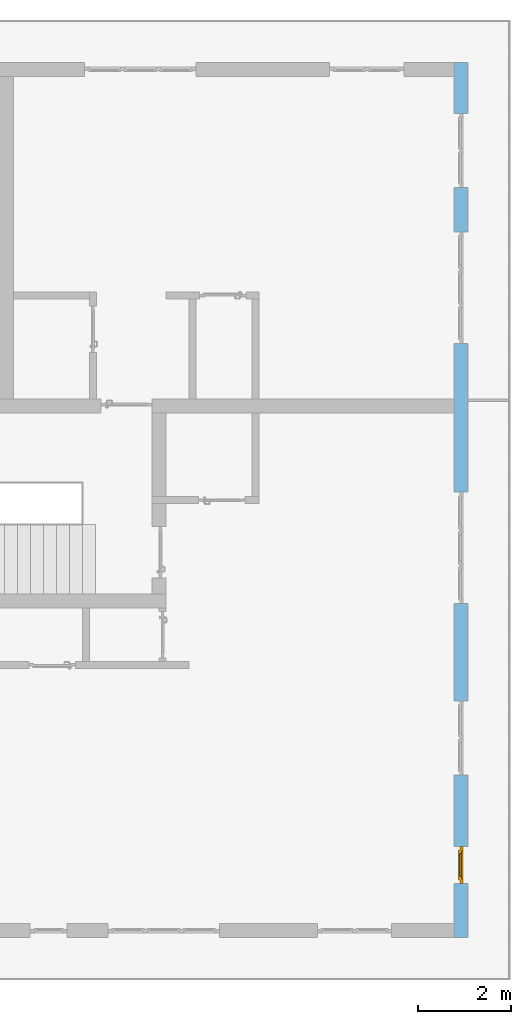
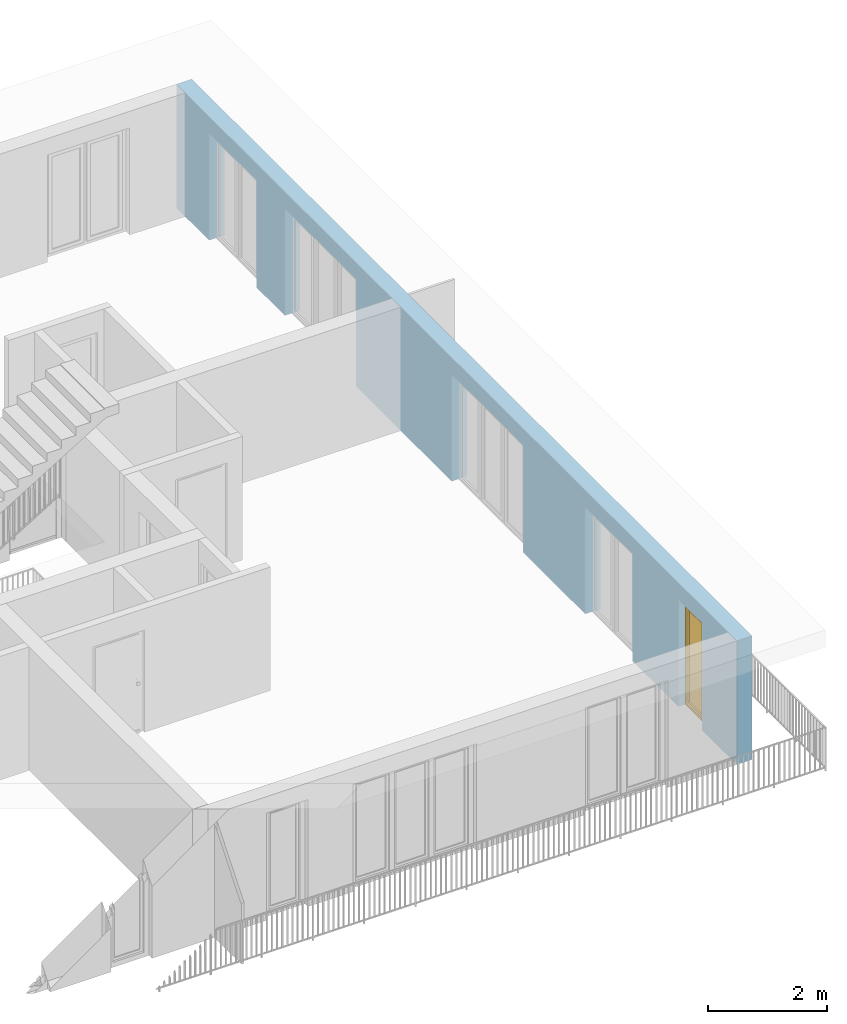
# One storey, part 19 of 48: 1 window, 5 openings, plus 1 element that does not belong to this part.
"""IFC4 building model written with IfcOpenShell, lengths in metres."""

from ifc_helpers import new_model, entity, si_unit, converted_unit, derived_unit, direction, frame, origin_with_axes, place, context, subcontext, project, spatial, polygons, source, transform, mapped, material, type_object, element, fill, save


model = new_model("IFC4")

# Units and contexts
model_context = context("Model", 3, precision=1e-05, world=origin_with_axes(), true_north=direction((0.0, 1.0)))
body_context = subcontext(model_context, "Body", "Model", "MODEL_VIEW")
ifc_project = project(units=[si_unit("LENGTHUNIT", "METRE"), si_unit("AREAUNIT", "SQUARE_METRE"), si_unit("VOLUMEUNIT", "CUBIC_METRE"), converted_unit("PLANEANGLEUNIT", "DEGREE", entity("IfcPlaneAngleMeasure", 0.0174532925199), si_unit("PLANEANGLEUNIT", "RADIAN"), dimensions=[0, 0, 0, 0, 0, 0, 0]), converted_unit("TIMEUNIT", "Year", entity("IfcTimeMeasure", 31556926.0), si_unit("TIMEUNIT", "SECOND"), dimensions=[0, 0, 1, 0, 0, 0, 0]), si_unit("MASSUNIT", "GRAM", prefix="KILO"), si_unit("THERMODYNAMICTEMPERATUREUNIT", "DEGREE_CELSIUS"), si_unit("LUMINOUSINTENSITYUNIT", "LUMEN"), si_unit("ENERGYUNIT", "JOULE", prefix="MEGA"), derived_unit("THERMALCONDUCTANCEUNIT", [(si_unit("POWERUNIT", "WATT"), 1), (si_unit("LENGTHUNIT", "METRE"), -1), (si_unit("THERMODYNAMICTEMPERATUREUNIT", "KELVIN"), -1)]), derived_unit("SPECIFICHEATCAPACITYUNIT", [(si_unit("ENERGYUNIT", "JOULE"), 1), (si_unit("MASSUNIT", "GRAM", prefix="KILO"), -1), (si_unit("THERMODYNAMICTEMPERATUREUNIT", "KELVIN"), -1)]), derived_unit("MASSDENSITYUNIT", [(si_unit("MASSUNIT", "GRAM", prefix="KILO"), 1), (si_unit("VOLUMEUNIT", "CUBIC_METRE"), -1)])], contexts=[model_context])

# Site, building, storey
site_placement = place(None, origin_with_axes())
site = spatial("IfcSite", under=ifc_project, at=site_placement, CompositionType="ELEMENT")
building_placement = place(site_placement, origin_with_axes())
building = spatial("IfcBuilding", under=site, at=building_placement, CompositionType="ELEMENT")
storey_placement = place(building_placement, frame((0.0, 0.0, 3.4), z_axis=(0.0, 0.0, 1.0), x_axis=(1.0, 0.0, 0.0)))
storey = spatial("IfcBuildingStorey", under=building, at=storey_placement, Name="1. Geschoss", CompositionType="ELEMENT", Elevation=3.4)

# Wall, openings, window
ifc_material = material()
wall_type = type_object("IfcWallType", Name="300", PredefinedType="NOTDEFINED")
wall_placement = place(storey_placement, frame((9.3378006196, -9.92881223104, 0.0), z_axis=(0.0, 0.0, 1.0), x_axis=(0.0, 1.0, 0.0)))
wall = element("IfcWall", 1, at=wall_placement, inside=storey, type_object=wall_type, material=ifc_material, Name="Wand-001", PredefinedType="NOTDEFINED", context=body_context, shape_type="Tessellation", body=[
    polygons([(1.16441876325, 0.1, 2.2), (1.96441876325, 0.1, 2.2), (1.96441876325, 0.0, 2.2), (1.16441876325, 0.0, 2.2), (1.16441876325, 0.3, 2.2), (1.96441876325, 0.3, 2.2), (1.96441876325, 0.1, 0.0), (1.96441876325, 0.0, 0.0), (18.85, 0.0, 2.54), (0.0, 0.0, 2.54), (0.0, 0.0, 0.0), (1.16441876325, 0.0, 0.0), (3.5, 0.0, 0.0), (3.5, 0.0, 2.2), (5.1, 0.0, 2.2), (5.1, 0.0, 0.0), (7.1921181063, 0.0, 0.0), (7.1921181063, 0.0, 2.2), (9.5921181063, 0.0, 2.2), (9.5921181063, 0.0, 0.0), (12.8, 0.0, 0.0), (12.8, 0.0, 2.2), (15.2, 0.0, 2.2), (15.2, 0.0, 0.0), (16.15, 0.0, 0.0), (16.15, 0.0, 2.2), (17.75, 0.0, 2.2), (17.75, 0.0, 0.0), (18.85, 0.0, 0.0), (1.16441876325, 0.1, 0.0), (1.16441876325, 0.3, 0.0), (0.0, 0.3, 0.0), (0.0, 0.3, 2.54), (18.85, 0.3, 2.54), (18.85, 0.3, 0.0), (17.75, 0.3, 0.0), (17.75, 0.3, 2.2), (16.15, 0.3, 2.2), (16.15, 0.3, 0.0), (15.2, 0.3, 0.0), (15.2, 0.3, 2.2), (12.8, 0.3, 2.2), (12.8, 0.3, 0.0), (9.5921181063, 0.3, 0.0), (9.5921181063, 0.3, 2.2), (7.1921181063, 0.3, 2.2), (7.1921181063, 0.3, 0.0), (5.1, 0.3, 0.0), (5.1, 0.3, 2.2), (3.5, 0.3, 2.2), (3.5, 0.3, 0.0), (1.96441876325, 0.3, 0.0), (3.5, 0.1, 0.0), (3.5, 0.1, 2.2), (5.1, 0.1, 2.2), (5.1, 0.1, 0.0), (7.1921181063, 0.1, 0.0), (7.1921181063, 0.1, 2.2), (9.5921181063, 0.1, 2.2), (9.5921181063, 0.1, 0.0), (12.8, 0.1, 0.0), (12.8, 0.1, 2.2), (15.2, 0.1, 2.2), (15.2, 0.1, 0.0), (16.15, 0.1, 0.0), (16.15, 0.1, 2.2), (17.75, 0.1, 2.2), (17.75, 0.1, 0.0)], [[[1, 2, 3, 4]], [[2, 1, 5, 6]], [[2, 7, 8, 3]], [[9, 10, 11, 12, 4, 3, 8, 13, 14, 15, 16, 17, 18, 19, 20, 21, 22, 23, 24, 25, 26, 27, 28, 29]], [[30, 1, 4, 12]], [[1, 30, 31, 5]], [[5, 31, 32, 33, 34, 35, 36, 37, 38, 39, 40, 41, 42, 43, 44, 45, 46, 47, 48, 49, 50, 51, 52, 6]], [[7, 2, 6, 52]], [[7, 52, 51, 53, 13, 8]], [[9, 34, 33, 10]], [[33, 32, 11, 10]], [[31, 30, 12, 11, 32]], [[14, 13, 53, 54]], [[15, 14, 54, 55]], [[16, 15, 55, 56]], [[56, 48, 47, 57, 17, 16]], [[57, 58, 18, 17]], [[58, 59, 19, 18]], [[59, 60, 20, 19]], [[60, 44, 43, 61, 21, 20]], [[22, 21, 61, 62]], [[23, 22, 62, 63]], [[24, 23, 63, 64]], [[64, 40, 39, 65, 25, 24]], [[65, 66, 26, 25]], [[66, 67, 27, 26]], [[67, 68, 28, 27]], [[36, 35, 29, 28, 68]], [[9, 29, 35, 34]], [[68, 67, 37, 36]], [[67, 66, 38, 37]], [[66, 65, 39, 38]], [[41, 40, 64, 63]], [[42, 41, 63, 62]], [[43, 42, 62, 61]], [[60, 59, 45, 44]], [[59, 58, 46, 45]], [[58, 57, 47, 46]], [[49, 48, 56, 55]], [[50, 49, 55, 54]], [[51, 50, 54, 53]]], closed=True),
])
opening_1_placement = place(wall_placement, frame((16.95, 0.0, 0.0), z_axis=(0.0, 0.0, 1.0), x_axis=(1.0, 0.0, 0.0)))
element("IfcOpeningElement", 2, at=opening_1_placement, cuts=wall, Name="Fenster-001", context=body_context, identifier="Reference", shape_type="Tessellation", body=[
    polygons([(0.8, 0.1, 0.0), (0.8, 0.1, 2.2), (0.8, -0.000999999999999, 2.2), (0.8, -0.000999999999999, 0.0), (0.8, 0.301, 0.0), (0.8, 0.301, 2.2), (-0.8, 0.1, 2.2), (-0.8, -0.000999999999999, 2.2), (-0.8, 0.301, 2.2), (-0.8, -0.000999999999999, 0.0), (-0.8, 0.1, 0.0), (-0.8, 0.301, 0.0)], [[[1, 2, 3, 4]], [[2, 1, 5, 6]], [[7, 8, 3, 2, 6, 9]], [[8, 10, 4, 3]], [[1, 4, 10, 11, 12, 5]], [[6, 5, 12, 9]], [[7, 11, 10, 8]], [[11, 7, 9, 12]]], closed=True),
])
opening_2_placement = place(wall_placement, frame((14.0, 0.0, 0.0), z_axis=(0.0, 0.0, 1.0), x_axis=(1.0, 0.0, 0.0)))
element("IfcOpeningElement", 3, at=opening_2_placement, cuts=wall, Name="Fenster-002", context=body_context, identifier="Reference", shape_type="Tessellation", body=[
    polygons([(1.2, 0.1, 0.0), (1.2, 0.1, 2.2), (1.2, -0.000999999999999, 2.2), (1.2, -0.000999999999999, 0.0), (1.2, 0.301, 0.0), (1.2, 0.301, 2.2), (-1.2, 0.1, 2.2), (-1.2, -0.000999999999999, 2.2), (-1.2, 0.301, 2.2), (-1.2, -0.000999999999999, 0.0), (-1.2, 0.1, 0.0), (-1.2, 0.301, 0.0)], [[[1, 2, 3, 4]], [[2, 1, 5, 6]], [[7, 8, 3, 2, 6, 9]], [[8, 10, 4, 3]], [[1, 4, 10, 11, 12, 5]], [[6, 5, 12, 9]], [[7, 11, 10, 8]], [[11, 7, 9, 12]]], closed=True),
])
opening_3_placement = place(wall_placement, frame((8.3921181063, 0.0, 0.0), z_axis=(0.0, 0.0, 1.0), x_axis=(1.0, 0.0, 0.0)))
element("IfcOpeningElement", 4, at=opening_3_placement, cuts=wall, Name="Fenster-002", context=body_context, identifier="Reference", shape_type="Tessellation", body=[
    polygons([(1.2, 0.1, 0.0), (1.2, 0.1, 2.2), (1.2, -0.000999999999999, 2.2), (1.2, -0.000999999999999, 0.0), (1.2, 0.301, 0.0), (1.2, 0.301, 2.2), (-1.2, 0.1, 2.2), (-1.2, -0.000999999999999, 2.2), (-1.2, 0.301, 2.2), (-1.2, -0.000999999999999, 0.0), (-1.2, 0.1, 0.0), (-1.2, 0.301, 0.0)], [[[1, 2, 3, 4]], [[2, 1, 5, 6]], [[7, 8, 3, 2, 6, 9]], [[8, 10, 4, 3]], [[1, 4, 10, 11, 12, 5]], [[6, 5, 12, 9]], [[7, 11, 10, 8]], [[11, 7, 9, 12]]], closed=True),
])
opening_4_placement = place(wall_placement, frame((4.3, 0.0, 0.0), z_axis=(0.0, 0.0, 1.0), x_axis=(1.0, 0.0, 0.0)))
element("IfcOpeningElement", 5, at=opening_4_placement, cuts=wall, Name="Fenster-001", context=body_context, identifier="Reference", shape_type="Tessellation", body=[
    polygons([(0.8, 0.1, 0.0), (0.8, 0.1, 2.2), (0.8, -0.000999999999999, 2.2), (0.8, -0.000999999999999, 0.0), (0.8, 0.301, 0.0), (0.8, 0.301, 2.2), (-0.8, 0.1, 2.2), (-0.8, -0.000999999999999, 2.2), (-0.8, 0.301, 2.2), (-0.8, -0.000999999999999, 0.0), (-0.8, 0.1, 0.0), (-0.8, 0.301, 0.0)], [[[1, 2, 3, 4]], [[2, 1, 5, 6]], [[7, 8, 3, 2, 6, 9]], [[8, 10, 4, 3]], [[1, 4, 10, 11, 12, 5]], [[6, 5, 12, 9]], [[7, 11, 10, 8]], [[11, 7, 9, 12]]], closed=True),
])
opening_5_placement = place(wall_placement, frame((1.56441876325, 0.0, 0.0), z_axis=(0.0, 0.0, 1.0), x_axis=(1.0, 0.0, 0.0)))
opening_5 = element("IfcOpeningElement", 6, at=opening_5_placement, cuts=wall, Name="Fenster-003", context=body_context, identifier="Reference", shape_type="Tessellation", body=[
    polygons([(0.4, 0.1, 0.0), (0.4, 0.1, 2.2), (0.4, -0.000999999999999, 2.2), (0.4, -0.000999999999999, 0.0), (0.4, 0.301, 0.0), (0.4, 0.301, 2.2), (-0.4, 0.1, 2.2), (-0.4, -0.000999999999999, 2.2), (-0.4, 0.301, 2.2), (-0.4, -0.000999999999999, 0.0), (-0.4, 0.1, 0.0), (-0.4, 0.301, 0.0)], [[[1, 2, 3, 4]], [[2, 1, 5, 6]], [[7, 8, 3, 2, 6, 9]], [[8, 10, 4, 3]], [[1, 4, 10, 11, 12, 5]], [[6, 5, 12, 9]], [[7, 11, 10, 8]], [[11, 7, 9, 12]]], closed=True),
])
window_type = type_object("IfcWindowType", Name="1-26", PartitioningType="SINGLE_PANEL", PredefinedType="WINDOW")
shared_shape = source(origin_with_axes(), body_context, "Body", "Tessellation", [
    polygons([(0.4, -0.07, 0.0), (0.3, -0.07, 0.1), (0.3, 0.0, 0.1), (0.4, 0.0, 0.0), (0.4, -0.07, 2.2), (0.3, -0.07, 2.1), (0.3, 0.0, 2.1), (0.4, 0.0, 2.2)], [[[1, 2, 3, 4]], [[1, 5, 6, 2]], [[2, 6, 7, 3]], [[4, 3, 7, 8]], [[5, 1, 4, 8]], [[6, 5, 8, 7]]], closed=True),
    polygons([(-0.4, -0.07, 0.0), (-0.4, -0.07, 2.2), (-0.4, 0.0, 2.2), (-0.4, 0.0, 0.0), (-0.3, -0.07, 0.1), (-0.3, -0.07, 2.1), (-0.3, 0.0, 2.1), (-0.3, 0.0, 0.1)], [[[1, 2, 3, 4]], [[1, 5, 6, 2]], [[2, 6, 7, 3]], [[4, 3, 7, 8]], [[5, 1, 4, 8]], [[6, 5, 8, 7]]], closed=True),
    polygons([(0.4, -0.07, 0.0), (-0.4, -0.07, 0.0), (-0.4, 0.0, 0.0), (0.4, 0.0, 0.0), (0.3, -0.07, 0.1), (0.0, -0.07, 0.1), (-0.3, -0.07, 0.1), (-0.3, 0.0, 0.1), (0.0, 0.0, 0.1), (0.3, 0.0, 0.1)], [[[1, 2, 3, 4]], [[1, 5, 6, 7, 2]], [[2, 7, 8, 3]], [[4, 3, 8, 9, 10]], [[5, 1, 4, 10]], [[6, 5, 10, 9]], [[7, 6, 9, 8]]], closed=True),
    polygons([(0.4, -0.07, 2.2), (0.3, -0.07, 2.1), (0.3, 0.0, 2.1), (0.4, 0.0, 2.2), (-0.4, -0.07, 2.2), (-0.3, -0.07, 2.1), (0.0, -0.07, 2.1), (0.0, 0.0, 2.1), (-0.3, 0.0, 2.1), (-0.4, 0.0, 2.2)], [[[1, 2, 3, 4]], [[1, 5, 6, 7, 2]], [[2, 7, 8, 3]], [[4, 3, 8, 9, 10]], [[5, 1, 4, 10]], [[6, 5, 10, 9]], [[7, 6, 9, 8]]], closed=True),
    polygons([(0.32, 0.0, 0.08), (0.25, 0.0, 0.15), (0.25, 0.03, 0.15), (0.32, 0.03, 0.08), (0.32, 0.0, 2.12), (0.25, 0.0, 2.05), (0.25, 0.03, 2.05), (0.32, 0.03, 2.12)], [[[1, 2, 3, 4]], [[1, 5, 6, 2]], [[2, 6, 7, 3]], [[4, 3, 7, 8]], [[5, 1, 4, 8]], [[6, 5, 8, 7]]], closed=True),
    polygons([(-0.32, 0.0, 0.08), (-0.32, 0.03, 0.08), (-0.25, 0.03, 0.15), (-0.25, 0.0, 0.15), (-0.32, 0.0, 2.12), (-0.32, 0.03, 2.12), (-0.25, 0.03, 2.05), (-0.25, 0.0, 2.05)], [[[1, 2, 3, 4]], [[5, 6, 2, 1]], [[2, 6, 7, 3]], [[4, 3, 7, 8]], [[1, 4, 8, 5]], [[8, 7, 6, 5]]], closed=True),
    polygons([(0.32, 0.0, 0.08), (-0.32, 0.0, 0.08), (-0.32, 0.03, 0.08), (0.32, 0.03, 0.08), (0.25, 0.0, 0.15), (-0.25, 0.0, 0.15), (-0.25, 0.03, 0.15), (0.25, 0.03, 0.15)], [[[1, 2, 3, 4]], [[1, 5, 6, 2]], [[2, 6, 7, 3]], [[4, 3, 7, 8]], [[5, 1, 4, 8]], [[6, 5, 8, 7]]], closed=True),
    polygons([(0.32, 0.0, 2.12), (0.32, 0.03, 2.12), (-0.32, 0.03, 2.12), (-0.32, 0.0, 2.12), (0.25, 0.0, 2.05), (0.25, 0.03, 2.05), (-0.25, 0.03, 2.05), (-0.25, 0.0, 2.05)], [[[1, 2, 3, 4]], [[5, 6, 2, 1]], [[2, 6, 7, 3]], [[4, 3, 7, 8]], [[1, 4, 8, 5]], [[8, 7, 6, 5]]], closed=True),
    polygons([(0.3, -0.03, 0.1), (0.25, -0.03, 0.15), (0.25, 0.0, 0.15), (0.3, 0.0, 0.1), (0.3, -0.03, 2.1), (0.25, -0.03, 2.05), (0.25, 0.0, 2.05), (0.3, 0.0, 2.1)], [[[1, 2, 3, 4]], [[1, 5, 6, 2]], [[2, 6, 7, 3]], [[4, 3, 7, 8]], [[5, 1, 4, 8]], [[6, 5, 8, 7]]], closed=True),
    polygons([(-0.3, -0.03, 0.1), (-0.3, 0.0, 0.1), (-0.25, 0.0, 0.15), (-0.25, -0.03, 0.15), (-0.3, -0.03, 2.1), (-0.3, 0.0, 2.1), (-0.25, 0.0, 2.05), (-0.25, -0.03, 2.05)], [[[1, 2, 3, 4]], [[5, 6, 2, 1]], [[2, 6, 7, 3]], [[4, 3, 7, 8]], [[1, 4, 8, 5]], [[8, 7, 6, 5]]], closed=True),
    polygons([(0.3, -0.03, 0.1), (-0.3, -0.03, 0.1), (-0.3, 0.0, 0.1), (0.3, 0.0, 0.1), (0.25, -0.03, 0.15), (-0.25, -0.03, 0.15), (-0.25, 0.0, 0.15), (0.25, 0.0, 0.15)], [[[1, 2, 3, 4]], [[1, 5, 6, 2]], [[2, 6, 7, 3]], [[4, 3, 7, 8]], [[5, 1, 4, 8]], [[6, 5, 8, 7]]], closed=True),
    polygons([(0.3, -0.03, 2.1), (0.3, 0.0, 2.1), (-0.3, 0.0, 2.1), (-0.3, -0.03, 2.1), (0.25, -0.03, 2.05), (0.25, 0.0, 2.05), (-0.25, 0.0, 2.05), (-0.25, -0.03, 2.05)], [[[1, 2, 3, 4]], [[5, 6, 2, 1]], [[2, 6, 7, 3]], [[4, 3, 7, 8]], [[1, 4, 8, 5]], [[8, 7, 6, 5]]], closed=True),
    polygons([(0.25, -0.005, 0.15), (-0.25, -0.005, 0.15), (-0.25, 0.005, 0.15), (0.25, 0.005, 0.15), (0.25, -0.005, 2.05), (-0.25, -0.005, 2.05), (-0.25, 0.005, 2.05), (0.25, 0.005, 2.05)], [[[1, 2, 3, 4]], [[1, 5, 6, 2]], [[2, 6, 7, 3]], [[4, 3, 7, 8]], [[5, 1, 4, 8]], [[6, 5, 8, 7]]], closed=True),
])
window_placement = place(opening_5_placement, frame((-0.4, 0.0, 0.0), z_axis=(0.0, 0.0, 1.0), x_axis=(1.0, 0.0, 0.0)))
window = element("IfcWindow", 7, at=window_placement, inside=storey, type_object=window_type, Name="Fenster-003", OverallHeight=2.2, OverallWidth=0.8, PredefinedType="WINDOW", context=body_context, shape_type="MappedRepresentation", body=[
    mapped(shared_shape, transform((0.4, 0.17, 0.0))),
])
fill(opening_5, window)

save(model, "model.ifc")
